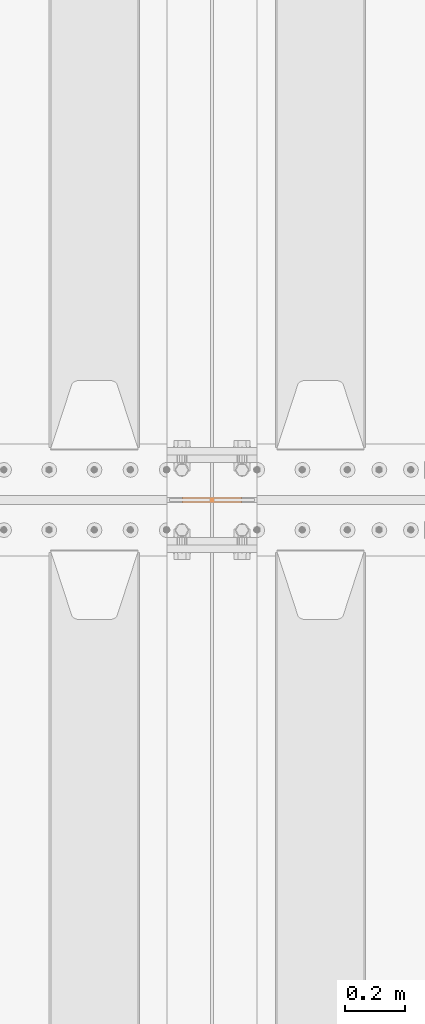
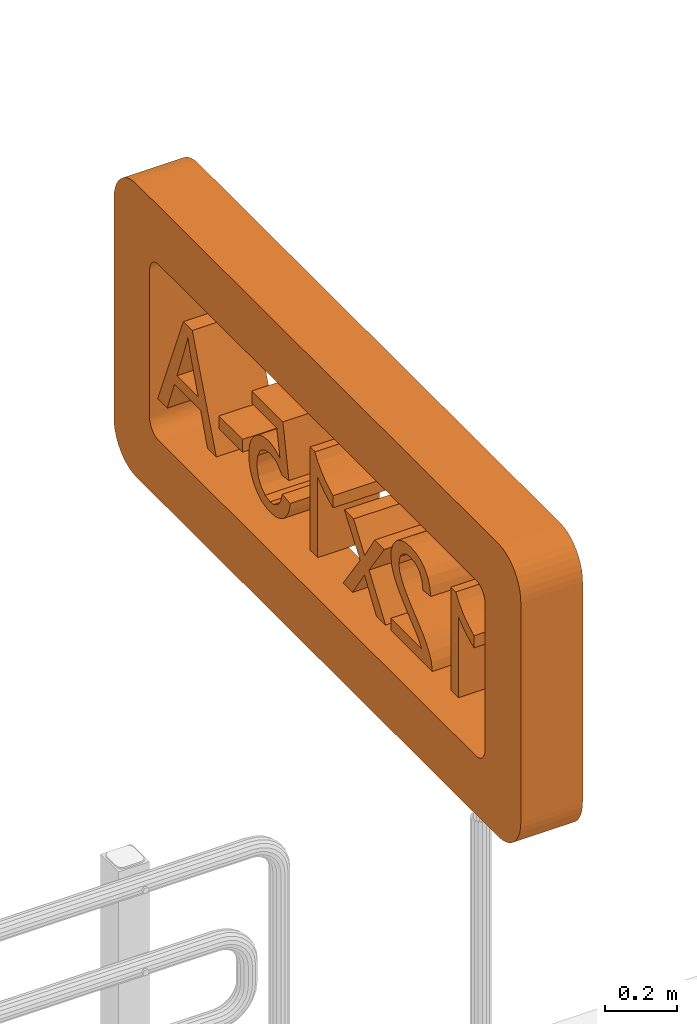
# One storey, part 240 of 240: 1 proxy.
"""IFC2X3 building model written with IfcOpenShell, lengths in millimetres."""

import ifcopenshell
import ifcopenshell.guid

model = None  # the IFC model being written
_history = None  # IfcOwnerHistory: only IFC2X3 demands one
_inside = {}  # id of a spatial element -> (the spatial element, [elements in it])
_under = {}  # id of a project, library or spatial element -> (it, [spatial elements below it])
_declared = {}  # id of a project -> (the project, [libraries it declares])
_typed = {}  # id of a type object -> (the type object, [elements of that type])
_made_of = {}  # id of a material, layer set ... -> (it, [elements and type objects made of it])


def new_model(schema):
    """Start an empty IFC model of exactly this schema.

    Asked for "IFC4X3", IfcOpenShell would pick the latest addendum, in which some entities
    have other attributes; the version numbers below select the first issue.
    IFC2X3 requires an IfcOwnerHistory on every rooted entity: one is made here for all.
    """
    global model, _history
    if schema == "IFC4X3":
        model = ifcopenshell.file(schema_version=(4, 3, 0, 0))
    else:
        model = ifcopenshell.file(schema=schema)
    _inside.clear()
    _under.clear()
    _declared.clear()
    _typed.clear()
    _made_of.clear()
    _history = None
    if model.schema == "IFC2X3":
        org = make("IfcOrganization", Name="unknown")
        user = make(
            "IfcPersonAndOrganization",
            ThePerson=make("IfcPerson", FamilyName="unknown"),
            TheOrganization=org,
        )
        app = make(
            "IfcApplication",
            ApplicationDeveloper=org,
            Version="unknown",
            ApplicationFullName="unknown",
            ApplicationIdentifier="unknown",
        )
        _history = make(
            "IfcOwnerHistory",
            OwningUser=user,
            OwningApplication=app,
            ChangeAction="ADDED",
            CreationDate=0,
        )
    return model


def make(cls, **values):
    """One entity of the class cls with the attributes given. An attribute that is None is left unset."""
    return model.create_entity(
        cls, **{name: value for name, value in values.items() if value is not None}
    )


def rooted(cls, **values):
    """An entity with a GlobalId (a new one), such as an element, a storey or a relation."""
    return make(cls, GlobalId=ifcopenshell.guid.new(), OwnerHistory=_history, **values)


def si_unit(unit_type, name, prefix=None):
    """IfcSIUnit, for example si_unit("LENGTHUNIT", "METRE", prefix="MILLI")."""
    return make("IfcSIUnit", UnitType=unit_type, Prefix=prefix, Name=name)


def assignment(units):
    """IfcUnitAssignment: the units of a project."""
    return None if units is None else make("IfcUnitAssignment", Units=units)


def point(xyz):
    """IfcCartesianPoint."""
    return None if xyz is None else make("IfcCartesianPoint", Coordinates=xyz)


def direction(xyz):
    """IfcDirection."""
    return None if xyz is None else make("IfcDirection", DirectionRatios=xyz)


def frame(location, z_axis=None, x_axis=None):
    """IfcAxis2Placement3D, a coordinate frame: its origin and axes. An axis left out is left unset."""
    return make(
        "IfcAxis2Placement3D",
        Location=point(location),
        Axis=direction(z_axis),
        RefDirection=direction(x_axis),
    )


def origin_with_axes():
    """The frame at (0, 0, 0) with the z axis (0, 0, 1) and the x axis (1, 0, 0) written out."""
    return frame((0.0, 0.0, 0.0), z_axis=(0.0, 0.0, 1.0), x_axis=(1.0, 0.0, 0.0))


def place(relative_to, where):
    """IfcLocalPlacement: puts the frame where relative to a parent placement (None: the world)."""
    return make(
        "IfcLocalPlacement", PlacementRelTo=relative_to, RelativePlacement=where
    )


def context(
    kind, dimensions, precision=None, world=None, true_north=None, identifier=None
):
    """IfcGeometricRepresentationContext, for example the 3D "Model" context."""
    return make(
        "IfcGeometricRepresentationContext",
        ContextIdentifier=identifier,
        ContextType=kind,
        CoordinateSpaceDimension=dimensions,
        Precision=precision,
        WorldCoordinateSystem=world,
        TrueNorth=true_north,
    )


def subcontext(parent, identifier, kind, view, scale=None):
    """IfcGeometricRepresentationSubContext, for example "Body" below "Model"."""
    return make(
        "IfcGeometricRepresentationSubContext",
        ContextIdentifier=identifier,
        ContextType=kind,
        ParentContext=parent,
        TargetScale=scale,
        TargetView=view,
    )


def project(units=None, contexts=None):
    """IfcProject with its units and contexts."""
    return rooted(
        "IfcProject",
        Name="project",
        RepresentationContexts=contexts,
        UnitsInContext=assignment(units),
    )


def spatial(cls, under=None, at=None, **own):
    """A site, building, storey or space (cls), placed at a placement, below another one or the project."""
    s = rooted(cls, ObjectPlacement=at, **own)
    if under is not None:
        _under.setdefault(under.id(), (under, []))[1].append(s)
    return s


def faces_of(points, faces, orient=None, outer=None):
    """IfcFace entities. A face is a list of loops; a loop is a list of indices into points, from 0.

    orient and outer hold one flag for each loop. By default every Orientation is true, the
    first loop of a face is its IfcFaceOuterBound and the others are IfcFaceBound.
    """
    made = []
    for i, loops in enumerate(faces):
        bounds = []
        for j, loop in enumerate(loops):
            is_outer = j == 0 if outer is None else outer[i][j]
            bounds.append(
                make(
                    "IfcFaceOuterBound" if is_outer else "IfcFaceBound",
                    Bound=make("IfcPolyLoop", Polygon=[points[k] for k in loop]),
                    Orientation=True if orient is None else orient[i][j],
                )
            )
        made.append(make("IfcFace", Bounds=bounds))
    return made


def faceted_brep(points, faces, orient=None, outer=None, voids=None):
    """IfcFacetedBrep: a solid bounded by flat faces; with voids (closed shells), ...WithVoids."""
    shared = [point(p) for p in points]
    hull = make("IfcClosedShell", CfsFaces=faces_of(shared, faces, orient, outer))
    if voids is None:
        return make("IfcFacetedBrep", Outer=hull)
    return make(
        "IfcFacetedBrepWithVoids",
        Outer=hull,
        Voids=[
            make(cls, CfsFaces=faces_of(shared, fs, o, b)) for cls, fs, o, b in voids
        ],
    )


def shape(context_of_items, identifier, shape_type, items):
    """IfcShapeRepresentation: the items that make up one representation, for example the "Body"."""
    return make(
        "IfcShapeRepresentation",
        ContextOfItems=context_of_items,
        RepresentationIdentifier=identifier,
        RepresentationType=shape_type,
        Items=items,
    )


def material(Name=None, Category=None):
    """IfcMaterial."""
    return make("IfcMaterial", Name=Name, Category=Category)


def made_of(thing, what):
    """Note that an element or type object is made of a material, layer set ...; save() writes the relation."""
    if what is not None:
        _made_of.setdefault(what.id(), (what, []))[1].append(thing)
    return thing


def type_object(cls, material=None, **own):
    """A type object (cls), such as IfcWallType, which elements share."""
    return made_of(rooted(cls, **own), material)


def element(
    cls,
    number,
    at=None,
    inside=None,
    cuts=None,
    type_object=None,
    material=None,
    context=None,
    identifier="Body",
    shape_type=None,
    held_by="IfcProductDefinitionShape",
    body=None,
    shapes=None,
    **own,
):
    """One element of the class cls, such as IfcWall. Its Tag is "e" and its number.

    at: its placement. inside: the storey or other place that contains it. cuts: it is an
    opening in that element (IfcRelVoidsElement). A single representation is given by context,
    identifier, shape_type and body (its items); several are given by shapes. held_by: the class
    of the entity that holds the representations. save() writes the other relations.
    """
    e = rooted(cls, Tag="e%d" % number, ObjectPlacement=at, **own)
    if body is not None:
        shapes = [shape(context, identifier, shape_type, body)]
    if shapes is not None:
        e.Representation = make(held_by, Representations=shapes)
    if inside is not None:
        _inside.setdefault(inside.id(), (inside, []))[1].append(e)
    if cuts is not None:
        rooted(
            "IfcRelVoidsElement", RelatingBuildingElement=cuts, RelatedOpeningElement=e
        )
    if type_object is not None:
        _typed.setdefault(type_object.id(), (type_object, []))[1].append(e)
    return made_of(e, material)


def aggregate(whole, parts):
    """IfcRelAggregates: a whole, such as a stair, and the parts it consists of."""
    return rooted("IfcRelAggregates", RelatingObject=whole, RelatedObjects=parts)


def save(model, path):
    """Write the relations noted so far, then the file.

    IfcRelAggregates (storeys below a building ...), IfcRelContainedInSpatialStructure (elements
    in a storey), IfcRelDefinesByType, IfcRelAssociatesMaterial and IfcRelDeclares: one each for
    every whole, place, type object, material and project.
    """
    for whole, parts in _under.values():
        aggregate(whole, parts)
    for where, things in _inside.values():
        rooted(
            "IfcRelContainedInSpatialStructure",
            RelatedElements=things,
            RelatingStructure=where,
        )
    for kind, things in _typed.values():
        rooted("IfcRelDefinesByType", RelatedObjects=things, RelatingType=kind)
    for what, things in _made_of.values():
        rooted("IfcRelAssociatesMaterial", RelatedObjects=things, RelatingMaterial=what)
    for by, libraries in _declared.values():
        rooted("IfcRelDeclares", RelatingContext=by, RelatedDefinitions=libraries)
    model.write(path)


model = new_model("IFC2X3")

# Units and contexts
model_context = context("Model", 3, precision=1e-05, world=origin_with_axes())
body_context = subcontext(model_context, "Body", "Model", "MODEL_VIEW")
ifc_project = project(units=[si_unit("LENGTHUNIT", "METRE", prefix="MILLI"), si_unit("AREAUNIT", "SQUARE_METRE"), si_unit("VOLUMEUNIT", "CUBIC_METRE"), si_unit("MASSUNIT", "GRAM", prefix="KILO"), si_unit("TIMEUNIT", "SECOND"), si_unit("PLANEANGLEUNIT", "RADIAN"), si_unit("SOLIDANGLEUNIT", "STERADIAN"), si_unit("THERMODYNAMICTEMPERATUREUNIT", "DEGREE_CELSIUS"), si_unit("LUMINOUSINTENSITYUNIT", "LUMEN")], contexts=[model_context])

# Site, building, storey
site_placement = place(None, origin_with_axes())
site = spatial("IfcSite", under=ifc_project, at=site_placement, CompositionType="ELEMENT")
building_placement = place(site_placement, origin_with_axes())
building = spatial("IfcBuilding", under=site, at=building_placement, Name="Standard", CompositionType="ELEMENT")
storey_placement = place(building_placement, origin_with_axes())
storey = spatial("IfcBuildingStorey", under=building, at=storey_placement, Name="Undefined", CompositionType="ELEMENT", Elevation=0.0)

# Proxy
ifc_material = material(Name="Misc_Undefined")
building_element_proxy_type = type_object("IfcBuildingElementProxyType", Name="12x15-A", PredefinedType="NOTDEFINED")
proxy_placement = place(storey_placement, frame((52840.0, 30000.0, 6500.0), z_axis=(0.0, 0.0, 1.0), x_axis=(0.0, 1.0, 0.0)))
element("IfcBuildingElementProxy", 1, at=proxy_placement, inside=storey, type_object=building_element_proxy_type, material=ifc_material, ObjectType="12x15-A", CompositionType="ELEMENT", context=body_context, shape_type="Brep", body=[
    faceted_brep([(748.551027033012, -100.0, 689.659303475266), (891.825343178472, -100.0, 339.646880140046), (891.825343178472, 100.0, 339.646880140046), (748.551027033012, 100.0, 689.659303475265), (838.938850641556, -100.0, 339.646880140046), (838.938850641556, 100.0, 339.646880140046), (798.552801795184, -100.0, 445.900651509666), (798.552801795184, 100.0, 445.900651509666), (665.374997861316, -100.0, 483.401982581297), (784.129212921482, -100.0, 483.401982581297), (784.129212921482, 100.0, 483.401982581297), (665.374997861316, 100.0, 483.401982581297), (747.58945444143, -100.0, 580.520814330905), (747.58945444143, 100.0, 580.520814330905), (736.050583342469, -100.0, 611.771923557264), (736.050583342469, 100.0, 611.771923557264), (726.915643722456, -100.0, 639.176742417301), (726.915643722456, 100.0, 639.176742417301), (722.588567060346, -100.0, 653.119544995216), (722.588567060346, 100.0, 653.119544995216), (715.857558919281, -100.0, 624.272367247807), (715.857558919281, 100.0, 624.272367247807), (707.203405595057, -100.0, 596.386762091979), (707.203405595057, 100.0, 596.386762091979), (703.83790152453, -100.0, 586.290249880386), (703.83790152453, 100.0, 586.290249880386), (651.912981579193, -100.0, 445.900651509666), (651.912981579193, 100.0, 445.900651509666), (613.450077915983, -100.0, 339.646880140046), (613.450077915983, 100.0, 339.646880140046), (564.40987574539, -100.0, 339.646880140046), (564.40987574539, 100.0, 339.646880140046), (699.030038566627, -100.0, 689.659303475266), (699.030038566627, 100.0, 689.659303475266), (417.770055529396, -100.0, 488.209845539199), (549.986286871685, -100.0, 488.209845539199), (549.986286871685, 100.0, 488.209845539199), (417.770055529396, 100.0, 488.209845539199), (549.986286871685, -100.0, 444.939078918085), (549.986286871685, 100.0, 444.939078918085), (417.770055529396, -100.0, 444.939078918085), (417.770055529396, 100.0, 444.939078918085), (366.325921879852, -100.0, 684.851440517365), (366.325921879852, -100.0, 643.984605375203), (366.325921879852, 100.0, 643.984605375203), (366.325921879852, 100.0, 684.851440517365), (226.897896100712, -100.0, 643.984605375203), (226.897896100712, 100.0, 643.984605375203), (208.147230564897, -100.0, 549.750491400336), (208.147230564897, 100.0, 549.750491400336), (262.476081989182, -100.0, 533.884543639262), (233.628904241774, -100.0, 528.595894385569), (233.628904241774, 100.0, 528.595894385569), (262.476081989182, 100.0, 533.884543639262), (224.97475091755, -100.0, 524.749604019248), (224.97475091755, 100.0, 524.749604019248), (202.858581311204, -100.0, 505.518152187643), (202.858581311204, 100.0, 505.518152187643), (199.012290944884, -100.0, 499.748716638162), (199.012290944884, 100.0, 499.748716638162), (158.626242098511, -100.0, 505.037365891853), (158.626242098511, 100.0, 505.037365891853), (192.281282803822, -100.0, 684.851440517365), (192.281282803822, 100.0, 684.851440517365), (274.014953088146, -100.0, 571.866661006682), (302.862130835554, -100.0, 568.020370640361), (302.862130835554, 100.0, 568.020370640361), (274.014953088146, 100.0, 571.866661006682), (328.824590808221, -100.0, 557.443072132978), (328.824590808221, 100.0, 557.443072132978), (351.421546710357, -100.0, 540.134765484533), (351.421546710357, 100.0, 540.134765484533), (234.109690537563, -100.0, 564.17408027404), (234.109690537563, 100.0, 564.17408027404), (261.514509397603, -100.0, 570.905088415102), (261.514509397603, 100.0, 570.905088415102), (291.32325973659, -100.0, 374.744279732726), (263.437654580761, -100.0, 368.974844183244), (243.725416453366, -100.0, 371.859561957986), (219.205315368068, -100.0, 385.802364535899), (204.781726494366, -100.0, 405.514602663295), (196.127573170143, -100.0, 435.323353002284), (150.933661365871, -100.0, 431.477062635962), (155.74152432377, -100.0, 407.437747846455), (167.280395422735, -100.0, 381.956074169579), (185.550274662761, -100.0, 360.320690859022), (206.224085381735, -100.0, 346.377888281108), (232.667331650195, -100.0, 336.762162365305), (263.437654580761, -100.0, 333.877444590564), (284.111465299738, -100.0, 335.319803477934), (311.516284159778, -100.0, 342.531597914786), (335.074812653493, -100.0, 356.474400492701), (355.267837076677, -100.0, 376.186638620096), (356.229409668256, -100.0, 377.628997507467), (371.133784837752, -100.0, 401.668312296973), (379.787938161975, -100.0, 428.592344861221), (382.672655936716, -100.0, 458.401095200209), (382.672655936716, -100.0, 462.247385566531), (378.826365570396, -100.0, 492.056135905519), (368.24906706301, -100.0, 518.018595878187), (265.360799763923, -100.0, 533.884543639262), (293.727191215541, -100.0, 528.11510808978), (316.804933413467, -100.0, 512.729946624495), (320.170437483997, -100.0, 508.883656258175), (333.151667470334, -100.0, 484.844341468667), (337.478744132441, -100.0, 454.554804833889), (336.997957836655, -100.0, 443.977506326506), (330.266949695593, -100.0, 415.130328579097), (315.843360821887, -100.0, 392.533372676961), (314.401001934519, -100.0, 391.091013789591), (330.266949695593, 100.0, 415.130328579097), (336.997957836655, 100.0, 443.977506326506), (337.478744132441, 100.0, 454.554804833889), (333.151667470334, 100.0, 484.844341468667), (320.170437483997, 100.0, 508.883656258175), (316.804933413467, 100.0, 512.729946624495), (293.727191215541, 100.0, 528.11510808978), (265.360799763923, 100.0, 533.884543639262), (368.24906706301, 100.0, 518.018595878187), (378.826365570396, 100.0, 492.056135905519), (382.672655936716, 100.0, 462.247385566531), (382.672655936716, 100.0, 458.401095200209), (379.787938161975, 100.0, 428.592344861221), (371.133784837752, 100.0, 401.668312296973), (356.229409668256, 100.0, 377.628997507467), (355.267837076677, 100.0, 376.186638620096), (335.074812653493, 100.0, 356.474400492701), (311.516284159778, 100.0, 342.531597914786), (284.111465299738, 100.0, 335.319803477934), (263.437654580761, 100.0, 333.877444590564), (232.667331650195, 100.0, 336.762162365305), (206.224085381735, 100.0, 346.377888281108), (185.550274662761, 100.0, 360.320690859022), (167.280395422735, 100.0, 381.956074169579), (155.74152432377, 100.0, 407.437747846455), (150.933661365871, 100.0, 431.477062635962), (196.127573170143, 100.0, 435.323353002284), (204.781726494366, 100.0, 405.514602663295), (219.205315368068, 100.0, 385.802364535899), (243.725416453366, 100.0, 371.859561957986), (263.437654580761, 100.0, 368.974844183244), (291.32325973659, 100.0, 374.744279732726), (314.401001934519, 100.0, 391.091013789591), (315.843360821887, 100.0, 392.533372676961), (40.8335996299284, -100.0, 691.101662362636), (40.8335996299284, -100.0, 339.646880140046), (40.8335996299284, 100.0, 339.646880140046), (40.8335996299284, 100.0, 691.101662362636), (-1.95638069539564, -100.0, 339.646880140046), (-1.95638069539564, 100.0, 339.646880140046), (-1.95638069539564, -100.0, 613.695068740424), (-1.95638069539564, 100.0, 613.695068740424), (-61.0930950775801, -100.0, 617.541359106744), (-37.5345665838649, -100.0, 633.88809316361), (-37.5345665838649, 100.0, 633.88809316361), (-61.0930950775801, 100.0, 617.541359106744), (-25.0341228933212, -100.0, 644.465391670993), (-25.0341228933212, 100.0, 644.465391670993), (-2.43716699118522, -100.0, 667.062347573129), (-2.43716699118522, 100.0, 667.062347573129), (12.4672081783101, -100.0, 689.659303475266), (12.4672081783101, 100.0, 689.659303475266), (13.4287807698893, -100.0, 691.101662362636), (13.4287807698893, 100.0, 691.101662362636), (-23.5917640059524, -100.0, 596.386762091979), (-23.5917640059524, 100.0, 596.386762091979), (-42.823215837554, -100.0, 583.886318401436), (-42.823215837554, 100.0, 583.886318401436), (-70.2280346975931, -100.0, 569.462729527731), (-70.2280346975931, 100.0, 569.462729527731), (-88.0171276418296, -100.0, 561.77014879509), (-88.0171276418296, 100.0, 561.77014879509), (-88.0171276418296, -100.0, 603.117770233041), (-88.0171276418296, 100.0, 603.117770233041), (-151.480918686128, -100.0, 593.502044317238), (-238.984024519934, -100.0, 473.786256665494), (-238.984024519934, 100.0, 473.786256665494), (-151.480918686128, 100.0, 593.502044317238), (-264.946484492601, -100.0, 505.518152187643), (-247.638177844154, -100.0, 530.03825327294), (-247.638177844154, 100.0, 530.03825327294), (-264.946484492601, 100.0, 505.518152187643), (-245.234246365202, -100.0, 533.403757343471), (-245.234246365202, 100.0, 533.403757343471), (-202.925052335671, -100.0, 593.502044317238), (-202.925052335671, 100.0, 593.502044317238), (-321.198481100044, -100.0, 593.502044317238), (-282.254791141044, -100.0, 533.884543639262), (-282.254791141044, 100.0, 533.884543639262), (-321.198481100044, 100.0, 593.502044317238), (-266.388843379969, -100.0, 508.402869962384), (-266.388843379969, 100.0, 508.402869962384), (-144.749910545066, -100.0, 339.646880140046), (-144.749910545066, 100.0, 339.646880140046), (-197.636403081982, -100.0, 339.646880140046), (-197.636403081982, 100.0, 339.646880140046), (-249.561323027316, -100.0, 418.495832649628), (-249.561323027316, 100.0, 418.495832649628), (-263.504125605228, -100.0, 439.650429664394), (-263.504125605228, 100.0, 439.650429664394), (-289.466585577895, -100.0, 471.382325186543), (-375.046546228539, -100.0, 593.502044317238), (-375.046546228539, 100.0, 593.502044317238), (-289.466585577895, 100.0, 471.382325186543), (-329.852634424267, -100.0, 339.646880140046), (-329.852634424267, 100.0, 339.646880140046), (-381.777554369604, -100.0, 339.646880140046), (-381.777554369604, 100.0, 339.646880140046), (-520.724793852951, -100.0, 691.101662362636), (-489.473684626595, -100.0, 688.216944587895), (-489.473684626595, 100.0, 688.216944587895), (-520.724793852951, 100.0, 691.101662362636), (-463.030438358135, -100.0, 678.601218672093), (-463.030438358135, 100.0, 678.601218672093), (-441.395055047582, -100.0, 663.216057206808), (-441.395055047582, 100.0, 663.216057206808), (-440.914268751789, -100.0, 663.216057206808), (-440.914268751789, 100.0, 663.216057206808), (-521.686366444534, -100.0, 655.523476474166), (-551.014330487731, -100.0, 650.234827220475), (-551.014330487731, 100.0, 650.234827220475), (-521.686366444534, 100.0, 655.523476474166), (-571.207354910919, -100.0, 636.772810938352), (-571.207354910919, 100.0, 636.772810938352), (-585.630943784621, -100.0, 614.175855036214), (-585.630943784621, 100.0, 614.175855036214), (-590.438806742524, -100.0, 585.328677288807), (-590.438806742524, 100.0, 585.328677288807), (-634.190359659424, -100.0, 590.136540246707), (-634.190359659424, 100.0, 590.136540246707), (-628.420924109945, -100.0, 620.906863177276), (-628.420924109945, 100.0, 620.906863177276), (-616.882053010981, -100.0, 646.388536854153), (-616.882053010981, 100.0, 646.388536854153), (-600.054532658327, -100.0, 665.139202389969), (-600.054532658327, 100.0, 665.139202389969), (-577.938363051981, -100.0, 680.043577559463), (-577.938363051981, 100.0, 680.043577559463), (-551.014330487731, -100.0, 688.216944587895), (-551.014330487731, 100.0, 688.216944587895), (-423.605962103346, -100.0, 640.619101304672), (-423.605962103346, 100.0, 640.619101304672), (-413.50944989175, -100.0, 614.656641332005), (-413.50944989175, 100.0, 614.656641332005), (-411.586304708591, -100.0, 593.982830613028), (-411.586304708591, 100.0, 593.982830613028), (-415.913381370705, -100.0, 565.135652865621), (-415.913381370705, 100.0, 565.135652865621), (-420.240458032815, -100.0, 552.635209175076), (-420.240458032815, 100.0, 552.635209175076), (-433.702474314938, -100.0, 529.07668068136), (-433.702474314938, 100.0, 529.07668068136), (-448.606849484433, -100.0, 509.845228849754), (-448.606849484433, 100.0, 509.845228849754), (-464.472797245508, -100.0, 493.49849479289), (-464.472797245508, 100.0, 493.49849479289), (-486.108180556064, -100.0, 473.786256665494), (-486.108180556064, 100.0, 473.786256665494), (-513.03221312031, -100.0, 450.227728171778), (-513.03221312031, 100.0, 450.227728171778), (-514.955358303472, -100.0, 448.304582988617), (-514.955358303472, 100.0, 448.304582988617), (-543.80253605088, -100.0, 423.78448190332), (-543.80253605088, 100.0, 423.78448190332), (-562.072415290902, -100.0, 407.437747846455), (-562.072415290902, 100.0, 407.437747846455), (-564.476346769858, -100.0, 404.553030071715), (-564.476346769858, 100.0, 404.553030071715), (-582.74622600988, -100.0, 380.994501577998), (-582.74622600988, 100.0, 380.994501577998), (-411.105518412802, -100.0, 380.994501577998), (-411.105518412802, 100.0, 380.994501577998), (-411.105518412802, -100.0, 339.646880140046), (-411.105518412802, 100.0, 339.646880140046), (-642.363726687858, -100.0, 339.646880140046), (-642.363726687858, 100.0, 339.646880140046), (-638.036650025748, -100.0, 368.494057887454), (-638.036650025748, 100.0, 368.494057887454), (-625.055420039411, -100.0, 394.456517860121), (-625.055420039411, 100.0, 394.456517860121), (-609.189472278336, -100.0, 416.091901170677), (-609.189472278336, 100.0, 416.091901170677), (-591.881165629893, -100.0, 434.842566706493), (-591.881165629893, 100.0, 434.842566706493), (-569.284209727757, -100.0, 455.035591129678), (-569.284209727757, 100.0, 455.035591129678), (-552.937475670893, -100.0, 468.978393707594), (-552.937475670893, 100.0, 468.978393707594), (-524.571084219275, -100.0, 493.49849479289), (-524.571084219275, 100.0, 493.49849479289), (-501.493342021349, -100.0, 514.653091807656), (-501.493342021349, 100.0, 514.653091807656), (-484.185035372902, -100.0, 532.922971047681), (-484.185035372902, 100.0, 532.922971047681), (-476.011668344472, -100.0, 543.500269555064), (-476.011668344472, 100.0, 543.500269555064), (-460.626506879184, -100.0, 570.905088415102), (-460.626506879184, 100.0, 570.905088415102), (-455.818643921284, -100.0, 594.944403204609), (-455.818643921284, 100.0, 594.944403204609), (-462.549652062346, -100.0, 622.349222064647), (-462.549652062346, 100.0, 622.349222064647), (-474.08852316131, -100.0, 638.215169825722), (-474.08852316131, 100.0, 638.215169825722), (-497.647051655025, -100.0, 652.157972403636), (-497.647051655025, 100.0, 652.157972403636), (-747.175139170107, -100.0, 691.101662362636), (-747.175139170107, -100.0, 339.646880140046), (-747.175139170107, 100.0, 339.646880140046), (-747.175139170107, 100.0, 691.101662362636), (-789.965119495431, -100.0, 339.646880140046), (-789.965119495431, 100.0, 339.646880140046), (-789.965119495431, -100.0, 613.695068740424), (-789.965119495431, 100.0, 613.695068740424), (-849.101833877616, -100.0, 617.541359106744), (-825.062519088111, -100.0, 633.88809316361), (-825.062519088111, 100.0, 633.88809316361), (-849.101833877616, 100.0, 617.541359106744), (-813.042861693357, -100.0, 644.465391670993), (-813.042861693357, 100.0, 644.465391670993), (-790.445905791221, -100.0, 667.062347573129), (-790.445905791221, 100.0, 667.062347573129), (-775.541530621726, -100.0, 689.659303475266), (-775.541530621726, 100.0, 689.659303475266), (-774.579958030146, -100.0, 691.101662362636), (-774.579958030146, 100.0, 691.101662362636), (-811.600502805988, -100.0, 596.386762091979), (-811.600502805988, 100.0, 596.386762091979), (-830.351168341804, -100.0, 583.886318401436), (-830.351168341804, 100.0, 583.886318401436), (-858.236773497629, -100.0, 569.462729527731), (-858.236773497629, 100.0, 569.462729527731), (-876.025866441865, -100.0, 561.77014879509), (-876.025866441865, 100.0, 561.77014879509), (-876.025866441865, -100.0, 603.117770233041), (-876.025866441865, 100.0, 603.117770233041), (937.5, 100.0, 750.0), (937.5, 100.0, 250.0), (937.5, -100.0, 250.0), (937.5, -100.0, 750.0), (936.884417029756, -100.0, 242.178276747988), (936.884417029756, 100.0, 242.178276747989), (935.052825814757, 100.0, 234.549150281253), (935.052825814757, -100.0, 234.549150281253), (932.050326209417, -100.0, 227.300475013023), (932.050326209417, 100.0, 227.300475013023), (927.950849718749, -100.0, 220.610737385377), (927.950849718749, 100.0, 220.610737385377), (916.889262614623, 100.0, 209.549150281253), (910.199524986976, 100.0, 205.449673790582), (910.199524986976, -100.0, 205.449673790582), (916.889262614623, -100.0, 209.549150281253), (922.855339059326, -100.0, 214.644660940673), (922.855339059326, 100.0, 214.644660940673), (902.950849718749, -100.0, 202.447174185242), (902.950849718749, 100.0, 202.447174185242), (895.321723252011, -100.0, 200.615582970243), (895.321723252011, 100.0, 200.615582970243), (887.5, 100.0, 200.0), (887.5, -100.0, 200.0), (-887.5, 100.0, 200.0), (-887.5, -100.0, 200.0), (-895.321723252011, -100.0, 200.615582970243), (-895.321723252011, 100.0, 200.615582970243), (-902.950849718749, 100.0, 202.447174185242), (-902.950849718749, -100.0, 202.447174185242), (-910.199524986976, -100.0, 205.449673790582), (-910.199524986976, 100.0, 205.449673790582), (-916.889262614623, -100.0, 209.549150281253), (-916.889262614623, 100.0, 209.549150281253), (-922.855339059326, 100.0, 214.644660940673), (-922.855339059326, -100.0, 214.644660940673), (-927.950849718749, -100.0, 220.610737385377), (-927.950849718749, 100.0, 220.610737385377), (-932.050326209417, 100.0, 227.300475013023), (-932.050326209417, -100.0, 227.300475013023), (-935.052825814757, -100.0, 234.549150281253), (-935.052825814757, 100.0, 234.549150281253), (-936.884417029756, -100.0, 242.178276747989), (-936.884417029756, 100.0, 242.178276747989), (-937.5, 100.0, 250.0), (-937.5, -100.0, 250.0), (-937.5, 100.0, 750.0), (-937.5, -100.0, 750.0), (-936.884417029756, -100.0, 757.821723252011), (-936.884417029756, 100.0, 757.821723252011), (-935.052825814757, 100.0, 765.450849718747), (-935.052825814757, -100.0, 765.450849718747), (-932.050326209417, -100.0, 772.699524986977), (-932.050326209417, 100.0, 772.699524986977), (-927.950849718749, -100.0, 779.389262614623), (-927.950849718749, 100.0, 779.389262614623), (-922.855339059326, 100.0, 785.355339059327), (-922.855339059326, -100.0, 785.355339059327), (-916.889262614623, -100.0, 790.450849718747), (-916.889262614623, 100.0, 790.450849718747), (-910.199524986976, 100.0, 794.550326209418), (-910.199524986976, -100.0, 794.550326209418), (-902.950849718749, -100.0, 797.552825814757), (-902.950849718749, 100.0, 797.552825814757), (-895.321723252011, -100.0, 799.384417029756), (-895.321723252011, 100.0, 799.384417029756), (-887.5, 100.0, 800.0), (-887.5, -100.0, 800.0), (887.5, 100.0, 800.0), (887.5, -100.0, 800.0), (895.321723252011, -100.0, 799.384417029756), (895.321723252011, 100.0, 799.384417029756), (902.950849718749, 100.0, 797.552825814757), (902.950849718749, -100.0, 797.552825814757), (910.199524986976, -100.0, 794.550326209418), (910.199524986976, 100.0, 794.550326209418), (916.889262614623, -100.0, 790.450849718747), (916.889262614623, 100.0, 790.450849718747), (922.855339059326, 100.0, 785.355339059327), (922.855339059326, -100.0, 785.355339059327), (927.950849718749, -100.0, 779.389262614623), (927.950849718749, 100.0, 779.389262614623), (932.050326209417, 100.0, 772.699524986977), (932.050326209417, -100.0, 772.699524986977), (935.052825814757, -100.0, 765.450849718747), (935.052825814757, 100.0, 765.450849718747), (936.884417029756, -100.0, 757.821723252011), (936.884417029756, 100.0, 757.821723252011), (1137.5, -100.0, 875.0), (1137.5, -100.0, 125.0), (1137.5, 100.0, 125.0), (1137.5, 100.0, 875.0), (1032.05430813003, -100.0, 1.5389574256078), (1032.05430813003, 100.0, 1.5389574256078), (1051.12712429687, 100.0, 6.11793546310582), (1051.12712429687, -100.0, 6.11793546310582), (1012.5, -100.0, 0.0), (1012.5, 100.0, 0.0), (1069.24881246744, -100.0, 13.6241844764545), (1069.24881246744, 100.0, 13.6241844764545), (1085.97315653656, -100.0, 23.8728757031322), (1085.97315653656, 100.0, 23.8728757031322), (1100.88834764832, 100.0, 36.6116523516821), (1100.88834764832, -100.0, 36.6116523516821), (1113.62712429687, -100.0, 51.5268434634409), (1113.62712429687, 100.0, 51.5268434634409), (1123.87581552354, 100.0, 68.2511875325563), (1123.87581552354, -100.0, 68.2511875325572), (1131.38206453689, -100.0, 86.3728757031313), (1131.38206453689, 100.0, 86.3728757031313), (1135.96104257439, -100.0, 105.445691869971), (1135.96104257439, 100.0, 105.445691869971), (-1012.5, -100.0, 0.0), (-1012.5, 100.0, 0.0), (-1135.96104257439, -100.0, 105.445691869971), (-1135.96104257439, 100.0, 105.445691869971), (-1131.38206453689, 100.0, 86.3728757031313), (-1131.38206453689, -100.0, 86.3728757031313), (-1137.5, -100.0, 125.0), (-1137.5, 100.0, 125.0), (-1123.87581552354, -100.0, 68.2511875325563), (-1123.87581552354, 100.0, 68.2511875325563), (-1113.62712429687, -100.0, 51.5268434634409), (-1113.62712429687, 100.0, 51.5268434634409), (-1100.88834764832, 100.0, 36.6116523516812), (-1100.88834764832, -100.0, 36.6116523516812), (-1085.97315653656, -100.0, 23.8728757031322), (-1085.97315653656, 100.0, 23.8728757031313), (-1069.24881246744, 100.0, 13.6241844764545), (-1069.24881246744, -100.0, 13.6241844764545), (-1051.12712429687, -100.0, 6.11793546310582), (-1051.12712429687, 100.0, 6.11793546310582), (-1032.05430813003, -100.0, 1.5389574256078), (-1032.05430813003, 100.0, 1.5389574256078), (-1137.5, -100.0, 875.0), (-1137.5, 100.0, 875.0), (-1032.05430813003, -100.0, 998.461042574392), (-1032.05430813003, 100.0, 998.461042574392), (-1051.12712429687, 100.0, 993.882064536894), (-1051.12712429687, -100.0, 993.882064536894), (-1012.5, -100.0, 1000.0), (-1012.5, 100.0, 1000.0), (-1069.24881246744, -100.0, 986.375815523546), (-1069.24881246744, 100.0, 986.375815523546), (-1085.97315653656, -100.0, 976.127124296869), (-1085.97315653656, 100.0, 976.127124296869), (-1100.88834764832, 100.0, 963.388347648319), (-1100.88834764832, -100.0, 963.388347648319), (-1113.62712429687, -100.0, 948.473156536559), (-1113.62712429687, 100.0, 948.473156536559), (-1123.87581552354, 100.0, 931.748812467444), (-1123.87581552354, -100.0, 931.748812467444), (-1131.38206453689, -100.0, 913.627124296869), (-1131.38206453689, 100.0, 913.627124296869), (-1135.96104257439, -100.0, 894.554308130029), (-1135.96104257439, 100.0, 894.554308130029), (1012.5, -100.0, 1000.0), (1012.5, 100.0, 1000.0), (1135.96104257439, -100.0, 894.554308130029), (1135.96104257439, 100.0, 894.554308130029), (1131.38206453689, 100.0, 913.627124296869), (1131.38206453689, -100.0, 913.627124296869), (1123.87581552354, -100.0, 931.748812467444), (1123.87581552354, 100.0, 931.748812467444), (1113.62712429687, -100.0, 948.473156536559), (1113.62712429687, 100.0, 948.473156536559), (1100.88834764832, 100.0, 963.388347648319), (1100.88834764832, -100.0, 963.388347648319), (1085.97315653656, -100.0, 976.127124296869), (1085.97315653656, 100.0, 976.127124296869), (1069.24881246744, 100.0, 986.375815523546), (1069.24881246744, -100.0, 986.375815523546), (1051.12712429687, -100.0, 993.882064536894), (1051.12712429687, 100.0, 993.882064536894), (1032.05430813003, -100.0, 998.461042574392), (1032.05430813003, 100.0, 998.461042574392)], [[[0, 1, 2, 3]], [[1, 4, 5, 2]], [[4, 6, 7, 5]], [[8, 9, 10, 11]], [[9, 12, 13, 10]], [[12, 14, 15, 13]], [[14, 16, 17, 15]], [[16, 18, 19, 17]], [[18, 20, 21, 19]], [[20, 22, 23, 21]], [[22, 24, 25, 23]], [[24, 8, 11, 25]], [[6, 26, 27, 7]], [[26, 28, 29, 27]], [[28, 30, 31, 29]], [[30, 32, 33, 31]], [[32, 0, 3, 33]], [[28, 26, 6, 4, 1, 0, 32, 30], [20, 18, 16, 14, 12, 9, 8, 24, 22]], [[3, 2, 5, 7, 27, 29, 31, 33], [13, 15, 17, 19, 21, 23, 25, 11, 10]], [[34, 35, 36, 37]], [[35, 38, 39, 36]], [[38, 40, 41, 39]], [[40, 34, 37, 41]], [[41, 37, 36, 39]], [[38, 35, 34, 40]], [[42, 43, 44, 45]], [[43, 46, 47, 44]], [[46, 48, 49, 47]], [[50, 51, 52, 53]], [[51, 54, 55, 52]], [[54, 56, 57, 55]], [[56, 58, 59, 57]], [[58, 60, 61, 59]], [[60, 62, 63, 61]], [[62, 42, 45, 63]], [[64, 65, 66, 67]], [[65, 68, 69, 66]], [[68, 70, 71, 69]], [[48, 72, 73, 49]], [[72, 74, 75, 73]], [[74, 64, 67, 75]], [[76, 77, 78, 79, 80, 81, 82, 83, 84, 85, 86, 87, 88, 89, 90, 91, 92, 93, 94, 95, 96, 97, 98, 99, 70, 68, 65, 64, 74, 72, 48, 46, 43, 42, 62, 60, 58, 56, 54, 51, 50, 100, 101, 102, 103, 104, 105, 106, 107, 108, 109]], [[110, 111, 112, 113, 114, 115, 116, 117, 53, 52, 55, 57, 59, 61, 63, 45, 44, 47, 49, 73, 75, 67, 66, 69, 71, 118, 119, 120, 121, 122, 123, 124, 125, 126, 127, 128, 129, 130, 131, 132, 133, 134, 135, 136, 137, 138, 139, 140, 141, 142, 143]], [[70, 99, 118, 71]], [[99, 98, 119, 118]], [[98, 97, 120, 119]], [[97, 96, 121, 120]], [[96, 95, 122, 121]], [[95, 94, 123, 122]], [[94, 93, 124, 123]], [[93, 92, 125, 124]], [[92, 91, 126, 125]], [[91, 90, 127, 126]], [[90, 89, 128, 127]], [[89, 88, 129, 128]], [[88, 87, 130, 129]], [[87, 86, 131, 130]], [[86, 85, 132, 131]], [[77, 76, 141, 140]], [[76, 109, 142, 141]], [[109, 108, 143, 142]], [[108, 107, 110, 143]], [[107, 106, 111, 110]], [[106, 105, 112, 111]], [[105, 104, 113, 112]], [[104, 103, 114, 113]], [[103, 102, 115, 114]], [[102, 101, 116, 115]], [[101, 100, 117, 116]], [[100, 50, 53, 117]], [[81, 80, 137, 136]], [[80, 79, 138, 137]], [[79, 78, 139, 138]], [[78, 77, 140, 139]], [[85, 84, 133, 132]], [[84, 83, 134, 133]], [[83, 82, 135, 134]], [[82, 81, 136, 135]], [[144, 145, 146, 147]], [[145, 148, 149, 146]], [[148, 150, 151, 149]], [[152, 153, 154, 155]], [[153, 156, 157, 154]], [[156, 158, 159, 157]], [[158, 160, 161, 159]], [[160, 162, 163, 161]], [[162, 144, 147, 163]], [[150, 164, 165, 151]], [[164, 166, 167, 165]], [[166, 168, 169, 167]], [[168, 170, 171, 169]], [[170, 172, 173, 171]], [[172, 152, 155, 173]], [[158, 156, 153, 152, 172, 170, 168, 166, 164, 150, 148, 145, 144, 162, 160]], [[146, 149, 151, 165, 167, 169, 171, 173, 155, 154, 157, 159, 161, 163, 147]], [[174, 175, 176, 177]], [[178, 179, 180, 181]], [[179, 182, 183, 180]], [[182, 184, 185, 183]], [[184, 174, 177, 185]], [[186, 187, 188, 189]], [[187, 190, 191, 188]], [[190, 178, 181, 191]], [[175, 192, 193, 176]], [[192, 194, 195, 193]], [[194, 196, 197, 195]], [[196, 198, 199, 197]], [[200, 201, 202, 203]], [[201, 186, 189, 202]], [[198, 204, 205, 199]], [[204, 206, 207, 205]], [[206, 200, 203, 207]], [[179, 178, 190, 187, 186, 201, 200, 206, 204, 198, 196, 194, 192, 175, 174, 184, 182]], [[176, 193, 195, 197, 199, 205, 207, 203, 202, 189, 188, 191, 181, 180, 183, 185, 177]], [[208, 209, 210, 211]], [[209, 212, 213, 210]], [[212, 214, 215, 213]], [[214, 216, 217, 215]], [[218, 219, 220, 221]], [[219, 222, 223, 220]], [[222, 224, 225, 223]], [[224, 226, 227, 225]], [[226, 228, 229, 227]], [[228, 230, 231, 229]], [[230, 232, 233, 231]], [[232, 234, 235, 233]], [[234, 236, 237, 235]], [[236, 238, 239, 237]], [[238, 208, 211, 239]], [[216, 240, 241, 217]], [[240, 242, 243, 241]], [[242, 244, 245, 243]], [[244, 246, 247, 245]], [[246, 248, 249, 247]], [[248, 250, 251, 249]], [[250, 252, 253, 251]], [[252, 254, 255, 253]], [[254, 256, 257, 255]], [[256, 258, 259, 257]], [[258, 260, 261, 259]], [[260, 262, 263, 261]], [[262, 264, 265, 263]], [[264, 266, 267, 265]], [[266, 268, 269, 267]], [[268, 270, 271, 269]], [[270, 272, 273, 271]], [[272, 274, 275, 273]], [[274, 276, 277, 275]], [[276, 278, 279, 277]], [[278, 280, 281, 279]], [[280, 282, 283, 281]], [[282, 284, 285, 283]], [[284, 286, 287, 285]], [[286, 288, 289, 287]], [[288, 290, 291, 289]], [[290, 292, 293, 291]], [[292, 294, 295, 293]], [[294, 296, 297, 295]], [[296, 298, 299, 297]], [[298, 300, 301, 299]], [[300, 302, 303, 301]], [[302, 304, 305, 303]], [[304, 218, 221, 305]], [[222, 219, 218, 304, 302, 300, 298, 296, 294, 292, 290, 288, 286, 284, 282, 280, 278, 276, 274, 272, 270, 268, 266, 264, 262, 260, 258, 256, 254, 252, 250, 248, 246, 244, 242, 240, 216, 214, 212, 209, 208, 238, 236, 234, 232, 230, 228, 226, 224]], [[275, 277, 279, 281, 283, 285, 287, 289, 291, 293, 295, 297, 299, 301, 303, 305, 221, 220, 223, 225, 227, 229, 231, 233, 235, 237, 239, 211, 210, 213, 215, 217, 241, 243, 245, 247, 249, 251, 253, 255, 257, 259, 261, 263, 265, 267, 269, 271, 273]], [[306, 307, 308, 309]], [[307, 310, 311, 308]], [[310, 312, 313, 311]], [[314, 315, 316, 317]], [[315, 318, 319, 316]], [[318, 320, 321, 319]], [[320, 322, 323, 321]], [[322, 324, 325, 323]], [[324, 306, 309, 325]], [[312, 326, 327, 313]], [[326, 328, 329, 327]], [[328, 330, 331, 329]], [[330, 332, 333, 331]], [[332, 334, 335, 333]], [[334, 314, 317, 335]], [[320, 318, 315, 314, 334, 332, 330, 328, 326, 312, 310, 307, 306, 324, 322]], [[308, 311, 313, 327, 329, 331, 333, 335, 317, 316, 319, 321, 323, 325, 309]], [[336, 337, 338, 339]], [[340, 338, 337, 341]], [[341, 342, 343, 340]], [[344, 343, 342, 345]], [[346, 344, 345, 347]], [[348, 349, 350, 351]], [[351, 352, 353, 348]], [[352, 346, 347, 353]], [[354, 350, 349, 355]], [[356, 354, 355, 357]], [[357, 358, 359, 356]], [[358, 360, 361, 359]], [[362, 361, 360, 363]], [[363, 364, 365, 362]], [[366, 365, 364, 367]], [[368, 366, 367, 369]], [[369, 370, 371, 368]], [[372, 371, 370, 373]], [[373, 374, 375, 372]], [[376, 375, 374, 377]], [[378, 376, 377, 379]], [[379, 380, 381, 378]], [[380, 382, 383, 381]], [[384, 383, 382, 385]], [[385, 386, 387, 384]], [[388, 387, 386, 389]], [[390, 388, 389, 391]], [[391, 392, 393, 390]], [[394, 393, 392, 395]], [[395, 396, 397, 394]], [[398, 397, 396, 399]], [[400, 398, 399, 401]], [[401, 402, 403, 400]], [[402, 404, 405, 403]], [[406, 405, 404, 407]], [[407, 408, 409, 406]], [[410, 409, 408, 411]], [[412, 410, 411, 413]], [[413, 414, 415, 412]], [[416, 415, 414, 417]], [[417, 418, 419, 416]], [[420, 419, 418, 421]], [[422, 420, 421, 423]], [[423, 336, 339, 422]], [[424, 425, 426, 427]], [[428, 429, 430, 431]], [[429, 428, 432, 433]], [[434, 431, 430, 435]], [[436, 437, 438, 439]], [[437, 436, 434, 435]], [[440, 441, 442, 443]], [[441, 440, 439, 438]], [[444, 443, 442, 445]], [[446, 447, 426, 425]], [[447, 446, 444, 445]], [[432, 448, 449, 433]], [[450, 451, 452, 453]], [[451, 450, 454, 455]], [[456, 453, 452, 457]], [[458, 459, 460, 461]], [[459, 458, 456, 457]], [[462, 463, 464, 465]], [[463, 462, 461, 460]], [[466, 465, 464, 467]], [[468, 469, 449, 448]], [[469, 468, 466, 467]], [[454, 470, 471, 455]], [[472, 473, 474, 475]], [[473, 472, 476, 477]], [[478, 475, 474, 479]], [[480, 481, 482, 483]], [[481, 480, 478, 479]], [[484, 485, 486, 487]], [[485, 484, 483, 482]], [[488, 487, 486, 489]], [[490, 491, 471, 470]], [[491, 490, 488, 489]], [[476, 492, 493, 477]], [[494, 495, 496, 497]], [[495, 494, 424, 427]], [[498, 497, 496, 499]], [[500, 501, 502, 503]], [[501, 500, 498, 499]], [[504, 505, 506, 507]], [[505, 504, 503, 502]], [[508, 507, 506, 509]], [[510, 511, 493, 492]], [[511, 510, 508, 509]], [[447, 445, 442, 441, 438, 437, 435, 430, 429, 433, 449, 469, 467, 464, 463, 460, 459, 457, 452, 451, 455, 471, 491, 489, 486, 485, 482, 481, 479, 474, 473, 477, 493, 511, 509, 506, 505, 502, 501, 499, 496, 495, 427, 426], [421, 418, 417, 414, 413, 411, 408, 407, 404, 402, 401, 399, 396, 395, 392, 391, 389, 386, 385, 382, 380, 379, 377, 374, 373, 370, 369, 367, 364, 363, 360, 358, 357, 355, 349, 348, 353, 347, 345, 342, 341, 337, 336, 423]], [[494, 497, 498, 500, 503, 504, 507, 508, 510, 492, 476, 472, 475, 478, 480, 483, 484, 487, 488, 490, 470, 454, 450, 453, 456, 458, 461, 462, 465, 466, 468, 448, 432, 428, 431, 434, 436, 439, 440, 443, 444, 446, 425, 424], [343, 344, 346, 352, 351, 350, 354, 356, 359, 361, 362, 365, 366, 368, 371, 372, 375, 376, 378, 381, 383, 384, 387, 388, 390, 393, 394, 397, 398, 400, 403, 405, 406, 409, 410, 412, 415, 416, 419, 420, 422, 339, 338, 340]]]),
])

save(model, "model.ifc")
